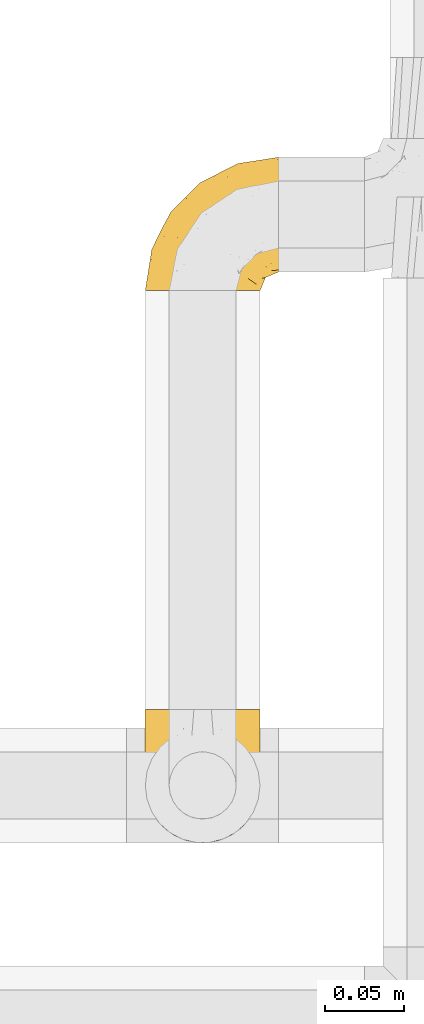
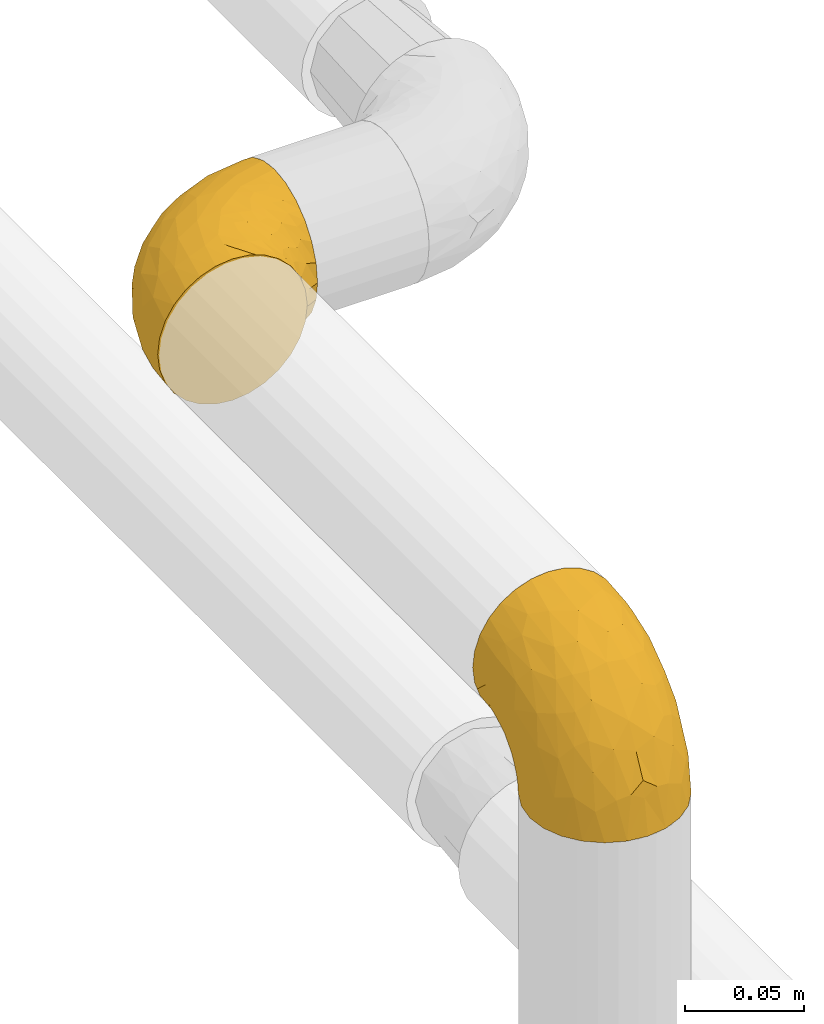
# One storey, part 21 of 39: 2 coverings.
"""IFC2X3 building model written with IfcOpenShell, lengths in millimetres."""

from ifc_helpers import new_model, entity, si_unit, converted_unit, derived_unit, direction, frame, origin, place, context, subcontext, project, spatial, faceted_brep, element, save


model = new_model("IFC2X3")

# Units and contexts
model_context = context("Model", 3, precision=0.01, world=origin(), true_north=direction((6.12303176911189e-17, 1.0)))
body_context = subcontext(model_context, "Body", "Model", "MODEL_VIEW")
ifc_project = project(units=[si_unit("LENGTHUNIT", "METRE", prefix="MILLI"), si_unit("AREAUNIT", "SQUARE_METRE"), si_unit("VOLUMEUNIT", "CUBIC_METRE"), converted_unit("PLANEANGLEUNIT", "DEGREE", entity("IfcRatioMeasure", 0.0174532925199433), si_unit("PLANEANGLEUNIT", "RADIAN"), dimensions=[0, 0, 0, 0, 0, 0, 0]), si_unit("MASSUNIT", "GRAM", prefix="KILO"), derived_unit("MASSDENSITYUNIT", [(si_unit("MASSUNIT", "GRAM", prefix="KILO"), 1), (si_unit("LENGTHUNIT", "METRE"), -3)]), derived_unit("MOMENTOFINERTIAUNIT", [(si_unit("LENGTHUNIT", "METRE"), 4)]), si_unit("TIMEUNIT", "SECOND"), si_unit("FREQUENCYUNIT", "HERTZ"), si_unit("THERMODYNAMICTEMPERATUREUNIT", "DEGREE_CELSIUS"), derived_unit("THERMALTRANSMITTANCEUNIT", [(si_unit("MASSUNIT", "GRAM", prefix="KILO"), 1), (si_unit("THERMODYNAMICTEMPERATUREUNIT", "KELVIN"), -1), (si_unit("TIMEUNIT", "SECOND"), -3)]), derived_unit("VOLUMETRICFLOWRATEUNIT", [(si_unit("LENGTHUNIT", "METRE"), 3), (si_unit("TIMEUNIT", "SECOND"), -1)]), derived_unit("MASSFLOWRATEUNIT", [(si_unit("MASSUNIT", "GRAM", prefix="KILO"), 1), (si_unit("TIMEUNIT", "SECOND"), -1)]), derived_unit("ROTATIONALFREQUENCYUNIT", [(si_unit("TIMEUNIT", "SECOND"), -1)]), si_unit("ELECTRICCURRENTUNIT", "AMPERE"), si_unit("ELECTRICVOLTAGEUNIT", "VOLT"), si_unit("POWERUNIT", "WATT"), si_unit("FORCEUNIT", "NEWTON", prefix="KILO"), si_unit("ILLUMINANCEUNIT", "LUX"), si_unit("LUMINOUSFLUXUNIT", "LUMEN"), si_unit("LUMINOUSINTENSITYUNIT", "CANDELA"), derived_unit("USERDEFINED", [(si_unit("MASSUNIT", "GRAM", prefix="KILO"), -1), (si_unit("LENGTHUNIT", "METRE"), -2), (si_unit("TIMEUNIT", "SECOND"), 3), (si_unit("LUMINOUSFLUXUNIT", "LUMEN"), 1)]), derived_unit("LINEARVELOCITYUNIT", [(si_unit("LENGTHUNIT", "METRE"), 1), (si_unit("TIMEUNIT", "SECOND"), -1)]), si_unit("PRESSUREUNIT", "PASCAL"), derived_unit("USERDEFINED", [(si_unit("LENGTHUNIT", "METRE"), -2), (si_unit("MASSUNIT", "GRAM", prefix="KILO"), 1), (si_unit("TIMEUNIT", "SECOND"), -2)]), derived_unit("LINEARFORCEUNIT", [(si_unit("MASSUNIT", "GRAM", prefix="KILO"), 1), (si_unit("LENGTHUNIT", "METRE"), 1), (si_unit("TIMEUNIT", "SECOND"), -2), (si_unit("LENGTHUNIT", "METRE"), -1)]), derived_unit("PLANARFORCEUNIT", [(si_unit("MASSUNIT", "GRAM", prefix="KILO"), 1), (si_unit("LENGTHUNIT", "METRE"), 1), (si_unit("TIMEUNIT", "SECOND"), -2), (si_unit("LENGTHUNIT", "METRE"), -2)])], contexts=[model_context])

# Site, building, storey
site_placement = place(None, origin())
site = spatial("IfcSite", under=ifc_project, at=site_placement, CompositionType="ELEMENT")
building_placement = place(site_placement, origin())
building = spatial("IfcBuilding", under=site, at=building_placement, CompositionType="ELEMENT")
storey_placement = place(building_placement, frame((0.0, 0.0, 24000.0)))
storey = spatial("IfcBuildingStorey", under=building, at=storey_placement, Name="07", CompositionType="ELEMENT", Elevation=24000.0)

# Coverings
covering_1_placement = place(storey_placement, frame((69427.22, 3185.76, 3362.2)))
element("IfcCovering", 1, at=covering_1_placement, inside=storey, Name=":ADSK_", ObjectType=":ADSK_", PredefinedType="INSULATION", context=body_context, shape_type="Brep", body=[
    faceted_brep([(37.8, 1.6, 74.0), (29.74, 1.6, 73.09), (22.08, 1.6, 70.41), (15.22, 1.6, 66.09), (9.49, 1.6, 60.36), (5.18, 1.6, 53.5), (2.5, 1.6, 45.85), (1.6, 1.6, 37.8), (2.5, 1.6, 29.74), (5.18, 1.6, 22.08), (9.5, 1.6, 15.22), (15.23, 1.6, 9.49), (22.09, 1.6, 5.18), (29.74, 1.6, 2.5), (37.8, 1.6, 1.6), (43.06, 1.6, 2.19), (45.85, 1.6, 2.5), (49.68, 1.6, 3.84), (53.51, 1.6, 5.18), (60.37, 1.6, 9.5), (66.1, 1.6, 15.23), (70.41, 1.6, 22.09), (73.09, 1.6, 29.74), (74.0, 1.6, 37.8), (73.09, 1.6, 45.85), (70.41, 1.6, 53.51), (66.09, 1.6, 60.37), (60.36, 1.6, 66.1), (53.5, 1.6, 70.41), (49.67, 1.6, 71.75), (45.85, 1.6, 73.09), (43.06, 1.6, 73.4), (85.8, 14.63, 28.43), (85.8, 18.25, 19.7), (85.8, 24.0, 12.2), (85.8, 27.75, 9.32), (85.8, 31.5, 6.45), (85.8, 35.86, 4.64), (85.8, 40.23, 2.83), (85.8, 44.31, 2.29), (85.8, 46.95, 1.94), (85.8, 49.6, 1.6), (85.8, 58.96, 2.83), (85.8, 67.7, 6.45), (85.8, 75.19, 12.2), (85.8, 80.95, 19.7), (85.8, 84.56, 28.43), (85.8, 85.8, 37.8), (85.8, 84.56, 47.16), (85.8, 80.95, 55.9), (85.8, 75.19, 63.39), (85.8, 67.7, 69.15), (85.8, 58.96, 72.76), (85.8, 49.6, 74.0), (85.8, 44.31, 73.3), (85.8, 40.23, 72.76), (85.8, 35.86, 70.95), (85.8, 31.5, 69.15), (85.8, 27.75, 66.27), (85.8, 24.0, 63.39), (85.8, 18.25, 55.9), (85.8, 14.63, 47.16), (85.8, 13.4, 37.8), (27.78, 59.61, 50.11), (26.99, 60.4, 37.8), (19.15, 51.32, 46.44), (59.78, 81.67, 37.8), (64.45, 82.49, 44.03), (67.99, 82.98, 37.8), (45.3, 73.87, 47.59), (53.86, 73.39, 57.17), (66.01, 81.11, 50.38), (70.92, 77.75, 58.65), (33.16, 16.46, 73.37), (49.16, 51.34, 71.27), (68.28, 63.37, 70.16), (50.64, 61.46, 66.97), (70.36, 54.83, 73.22), (67.43, 45.94, 74.0), (74.88, 47.42, 74.0), (77.61, 47.97, 74.0), (80.34, 48.51, 74.0), (65.68, 70.77, 64.86), (24.84, 15.75, 70.93), (11.5, 39.56, 45.19), (5.67, 21.48, 48.57), (13.35, 36.01, 54.32), (39.73, 34.58, 72.94), (41.45, 19.96, 74.0), (44.05, 23.86, 74.0), (46.65, 27.75, 74.0), (49.25, 31.64, 74.0), (51.85, 35.54, 74.0), (35.98, 46.13, 68.72), (57.18, 48.41, 73.34), (18.48, 16.74, 67.28), (13.36, 21.75, 61.7), (7.85, 16.31, 55.94), (4.42, 19.4, 37.8), (20.15, 48.77, 53.02), (31.91, 58.66, 57.31), (38.88, 7.05, 74.0), (39.97, 12.51, 74.0), (21.9, 34.87, 64.86), (22.4, 45.71, 59.15), (28.44, 30.95, 70.05), (41.69, 67.5, 55.98), (48.04, 75.69, 37.8), (33.67, 53.35, 63.54), (44.49, 64.73, 61.4), (5.72, 27.61, 37.8), (17.68, 51.09, 37.8), (11.7, 39.35, 37.8), (55.75, 38.14, 74.0), (59.64, 40.74, 74.0), (63.53, 43.34, 74.0), (36.3, 69.71, 37.8), (69.92, 30.92, 70.9), (69.03, 26.47, 69.2), (74.68, 24.1, 65.83), (79.55, 42.08, 73.31), (79.54, 27.56, 67.07), (81.25, 22.68, 62.53), (76.19, 12.9, 52.3), (72.4, 10.56, 54.94), (75.54, 9.38, 46.54), (63.7, 30.49, 72.08), (66.91, 37.21, 73.17), (72.9, 15.4, 59.32), (77.88, 16.56, 56.36), (80.8, 14.21, 48.99), (80.78, 19.1, 58.36), (60.93, 6.65, 66.05), (66.56, 9.22, 61.56), (58.7, 13.56, 68.98), (46.01, 10.43, 73.26), (80.23, 32.68, 70.05), (70.42, 40.02, 73.39), (74.75, 33.01, 70.87), (68.99, 13.09, 61.17), (51.42, 11.85, 71.9), (71.01, 20.93, 65.19), (76.08, 6.64, 37.8), (73.72, 5.68, 46.04), (71.61, 5.7, 52.15), (63.33, 14.76, 66.57), (77.45, 9.94, 37.8), (52.1, 25.2, 73.34), (50.98, 19.66, 72.91), (80.75, 11.31, 37.8), (76.87, 39.13, 72.75), (63.89, 24.56, 70.14), (57.77, 25.09, 72.14), (66.53, 18.54, 66.28), (57.73, 30.86, 73.22), (80.78, 19.1, 17.23), (80.8, 14.22, 26.6), (81.26, 22.68, 13.06), (38.88, 7.05, 1.6), (39.97, 12.51, 1.6), (73.72, 5.68, 29.56), (72.41, 10.57, 20.66), (71.61, 5.7, 23.45), (66.57, 9.22, 14.04), (74.88, 47.42, 1.6), (80.34, 48.51, 1.6), (83.07, 49.05, 1.6), (77.88, 16.56, 19.23), (76.2, 12.9, 23.3), (72.91, 15.39, 16.29), (77.2, 27.52, 8.09), (74.75, 33.0, 4.72), (80.23, 32.67, 5.54), (51.43, 11.86, 3.69), (76.87, 39.13, 2.84), (66.92, 37.21, 2.42), (69.93, 30.92, 4.69), (63.71, 30.49, 3.51), (70.42, 40.02, 2.2), (75.54, 9.38, 29.05), (79.55, 42.08, 2.29), (60.94, 6.65, 9.55), (69.0, 13.09, 14.43), (46.02, 10.43, 2.33), (57.77, 25.08, 3.45), (57.73, 30.85, 2.37), (63.89, 24.56, 5.45), (71.03, 20.93, 10.41), (51.53, 19.57, 2.81), (58.72, 13.56, 6.62), (41.45, 19.96, 1.6), (74.69, 24.1, 9.76), (63.35, 14.76, 9.03), (49.25, 31.64, 1.6), (56.44, 20.0, 4.15), (51.59, 25.27, 2.17), (44.05, 23.86, 1.6), (59.64, 40.74, 1.6), (55.75, 38.14, 1.6), (67.43, 45.94, 1.6), (63.53, 43.34, 1.6), (69.03, 26.46, 6.39), (66.54, 18.54, 9.32), (46.65, 27.75, 1.6), (51.85, 35.54, 1.6), (49.16, 51.33, 4.32), (70.36, 54.83, 2.37), (57.19, 48.41, 2.25), (22.41, 45.7, 16.43), (31.92, 58.67, 18.27), (33.68, 53.34, 12.04), (50.63, 61.46, 8.62), (35.99, 46.13, 6.87), (21.91, 34.86, 10.72), (39.73, 34.58, 2.64), (27.78, 59.61, 25.48), (41.7, 67.49, 19.59), (68.28, 63.37, 5.43), (64.45, 82.49, 31.57), (66.0, 81.11, 25.21), (28.45, 30.94, 5.53), (70.92, 77.75, 16.94), (65.68, 70.77, 10.73), (53.85, 73.39, 18.42), (13.35, 36.01, 21.26), (5.67, 21.48, 27.01), (11.5, 39.57, 30.39), (33.16, 16.45, 2.22), (13.37, 21.75, 13.88), (18.49, 16.74, 8.3), (45.3, 73.87, 28.0), (19.14, 51.31, 29.14), (20.15, 48.77, 22.56), (7.85, 16.32, 19.64), (44.48, 64.71, 14.18), (24.85, 15.75, 4.66)], [[[0, 1, 2, 3, 4, 5, 6, 7, 8, 9, 10, 11, 12, 13, 14, 15, 16, 17, 18, 19, 20, 21, 22, 23, 24, 25, 26, 27, 28, 29, 30, 31]], [[32, 33, 34, 35, 36, 37, 38, 39, 40, 41, 42, 43, 44, 45, 46, 47, 48, 49, 50, 51, 52, 53, 54, 55, 56, 57, 58, 59, 60, 61, 62]], [[63, 64, 65]], [[66, 67, 68]], [[69, 70, 71]], [[71, 70, 72]], [[73, 1, 0]], [[74, 75, 76]], [[49, 48, 71]], [[77, 78, 79, 80, 81, 53]], [[50, 82, 51]], [[72, 50, 49]], [[2, 1, 83]], [[84, 85, 86]], [[87, 88, 89, 90, 91, 92]], [[53, 52, 77]], [[93, 74, 76]], [[5, 85, 6]], [[94, 78, 77]], [[95, 3, 2]], [[95, 96, 3]], [[75, 51, 82]], [[85, 5, 97]], [[50, 72, 82]], [[97, 5, 4]], [[85, 98, 6]], [[94, 87, 92]], [[74, 77, 75]], [[99, 100, 63]], [[96, 4, 3]], [[73, 0, 101, 102, 88]], [[96, 103, 104]], [[48, 68, 67]], [[84, 99, 65]], [[105, 83, 73]], [[105, 95, 83]], [[100, 106, 63]], [[86, 96, 104]], [[97, 86, 85]], [[67, 107, 69]], [[100, 108, 109]], [[84, 110, 85]], [[93, 87, 74]], [[96, 95, 103]], [[69, 71, 67]], [[70, 69, 106]], [[4, 96, 97]], [[86, 97, 96]], [[83, 95, 2]], [[103, 95, 105]], [[93, 103, 105]], [[103, 108, 104]], [[75, 77, 52]], [[94, 77, 74]], [[51, 75, 52]], [[75, 82, 76]], [[109, 82, 70]], [[93, 76, 108]], [[88, 87, 73]], [[105, 73, 87]], [[84, 86, 99]], [[84, 111, 112, 110]], [[98, 85, 110]], [[98, 7, 6]], [[73, 83, 1]], [[71, 72, 49]], [[82, 72, 70]], [[87, 94, 74]], [[94, 92, 113, 114, 115, 78]], [[48, 47, 68]], [[48, 67, 71]], [[100, 104, 108]], [[99, 86, 104]], [[109, 108, 76]], [[100, 109, 106]], [[82, 109, 76]], [[106, 109, 70]], [[100, 99, 104]], [[99, 63, 65]], [[69, 116, 63]], [[111, 84, 65]], [[64, 63, 116]], [[64, 111, 65]], [[63, 106, 69]], [[103, 93, 108]], [[87, 93, 105]], [[107, 67, 66]], [[107, 116, 69]], [[117, 118, 119]], [[80, 120, 55]], [[121, 119, 122]], [[120, 56, 55]], [[123, 124, 125]], [[114, 126, 127]], [[101, 0, 31, 30, 102]], [[123, 128, 124]], [[129, 123, 130]], [[60, 122, 131]], [[132, 133, 134]], [[29, 28, 135]], [[131, 61, 60]], [[122, 60, 59]], [[136, 137, 138]], [[124, 128, 139]], [[132, 27, 26]], [[131, 130, 61]], [[140, 135, 28]], [[102, 29, 135]], [[119, 118, 141]], [[58, 136, 121]], [[140, 28, 27]], [[54, 53, 81, 80, 55]], [[23, 142, 143]], [[24, 144, 25]], [[25, 144, 133]], [[26, 25, 133]], [[134, 133, 145]], [[125, 142, 146]], [[124, 143, 125]], [[147, 90, 148]], [[124, 144, 143]], [[149, 125, 146]], [[150, 57, 56]], [[137, 78, 115]], [[130, 62, 61]], [[132, 140, 27]], [[151, 152, 153]], [[140, 134, 148]], [[148, 89, 140]], [[120, 78, 150]], [[115, 127, 137]], [[137, 136, 150]], [[78, 120, 80, 79]], [[150, 56, 120]], [[91, 154, 92]], [[127, 117, 138]], [[144, 24, 143]], [[133, 144, 124]], [[152, 91, 147]], [[145, 152, 134]], [[23, 143, 24]], [[142, 125, 143]], [[130, 125, 149]], [[128, 123, 129]], [[141, 129, 119]], [[124, 139, 133]], [[125, 130, 123]], [[62, 130, 149]], [[128, 153, 139]], [[145, 139, 153]], [[92, 154, 113]], [[127, 115, 114]], [[117, 127, 126]], [[118, 117, 126]], [[121, 117, 119]], [[138, 137, 127]], [[78, 137, 150]], [[151, 118, 126]], [[118, 151, 141]], [[153, 128, 141]], [[129, 141, 128]], [[102, 30, 29]], [[140, 88, 135]], [[88, 102, 135]], [[133, 132, 26]], [[140, 132, 134]], [[121, 122, 59]], [[131, 119, 129]], [[121, 59, 58]], [[121, 138, 117]], [[136, 58, 57]], [[150, 136, 57]], [[121, 136, 138]], [[119, 131, 122]], [[131, 129, 130]], [[139, 145, 133]], [[152, 145, 153]], [[89, 148, 90]], [[89, 88, 140]], [[147, 134, 152]], [[134, 147, 148]], [[126, 114, 113]], [[152, 154, 91]], [[91, 90, 147]], [[151, 153, 141]], [[154, 151, 126]], [[151, 154, 152]], [[113, 154, 126]], [[155, 32, 156]], [[33, 157, 34]], [[62, 149, 156]], [[15, 14, 158, 159, 16]], [[160, 23, 22]], [[161, 162, 163]], [[40, 39, 38, 164, 165, 166, 41]], [[167, 168, 169]], [[157, 170, 34]], [[171, 172, 170]], [[18, 173, 19]], [[174, 37, 36]], [[175, 176, 177]], [[178, 171, 175]], [[146, 179, 149]], [[168, 179, 161]], [[161, 160, 162]], [[162, 160, 22]], [[38, 37, 180]], [[20, 19, 181]], [[21, 20, 163]], [[161, 182, 169]], [[18, 183, 173]], [[184, 185, 186]], [[169, 187, 167]], [[188, 189, 173]], [[159, 190, 183]], [[17, 159, 183]], [[156, 179, 168]], [[191, 157, 155]], [[192, 163, 189]], [[21, 162, 22]], [[146, 142, 179]], [[181, 163, 20]], [[185, 184, 193]], [[178, 172, 171]], [[167, 156, 168]], [[184, 194, 195]], [[181, 173, 189]], [[173, 196, 188]], [[197, 177, 198]], [[199, 164, 180]], [[180, 164, 38]], [[200, 178, 175]], [[37, 174, 180]], [[199, 180, 174]], [[175, 197, 200]], [[177, 176, 201]], [[163, 162, 21]], [[160, 161, 179]], [[192, 184, 202]], [[194, 189, 188]], [[179, 142, 160]], [[23, 160, 142]], [[169, 168, 161]], [[155, 156, 167]], [[182, 161, 163]], [[202, 186, 187]], [[62, 156, 32]], [[179, 156, 149]], [[192, 182, 163]], [[202, 169, 182]], [[176, 175, 171]], [[174, 178, 199]], [[197, 175, 177]], [[170, 176, 171]], [[201, 176, 191]], [[199, 178, 200]], [[178, 174, 172]], [[187, 201, 191]], [[201, 187, 186]], [[167, 187, 191]], [[169, 202, 187]], [[173, 183, 190]], [[17, 16, 159]], [[173, 181, 19]], [[163, 181, 189]], [[155, 157, 33]], [[170, 157, 191]], [[176, 170, 191]], [[35, 170, 172]], [[35, 172, 36]], [[34, 170, 35]], [[174, 36, 172]], [[32, 155, 33]], [[191, 155, 167]], [[192, 189, 194]], [[182, 192, 202]], [[185, 198, 177]], [[183, 18, 17]], [[196, 173, 190]], [[196, 203, 188]], [[201, 186, 177]], [[202, 184, 186]], [[188, 195, 194]], [[204, 185, 193]], [[188, 203, 195]], [[192, 194, 184]], [[203, 193, 195]], [[184, 195, 193]], [[198, 185, 204]], [[186, 185, 177]], [[205, 206, 207]], [[208, 209, 210]], [[210, 211, 212]], [[210, 213, 208]], [[214, 204, 193, 203, 196, 190]], [[206, 41, 166, 165, 164, 199]], [[215, 216, 209]], [[206, 217, 42]], [[218, 46, 219]], [[207, 214, 205]], [[212, 214, 220]], [[221, 219, 45]], [[45, 219, 46]], [[221, 222, 223]], [[224, 225, 226]], [[222, 44, 43]], [[222, 217, 211]], [[220, 214, 227]], [[227, 190, 159, 158, 14]], [[217, 43, 42]], [[14, 13, 227]], [[225, 9, 8]], [[10, 228, 11]], [[11, 229, 12]], [[208, 213, 228]], [[228, 229, 11]], [[230, 219, 223]], [[231, 232, 226]], [[231, 64, 215]], [[225, 233, 9]], [[229, 213, 220]], [[233, 10, 9]], [[110, 225, 98]], [[41, 206, 42]], [[222, 211, 234]], [[224, 228, 233]], [[225, 8, 98]], [[221, 45, 44]], [[226, 110, 112, 111]], [[12, 229, 235]], [[46, 218, 68]], [[230, 107, 218]], [[223, 234, 216]], [[107, 66, 218]], [[224, 233, 225]], [[228, 10, 233]], [[213, 229, 228]], [[235, 229, 220]], [[208, 228, 224]], [[212, 213, 210]], [[207, 206, 199]], [[205, 211, 217]], [[205, 217, 206]], [[43, 217, 222]], [[212, 211, 205]], [[210, 209, 234]], [[227, 13, 235]], [[214, 190, 227]], [[110, 226, 225]], [[232, 231, 215]], [[8, 7, 98]], [[227, 235, 220]], [[13, 12, 235]], [[222, 221, 44]], [[219, 221, 223]], [[207, 199, 200, 197, 198, 204]], [[214, 207, 204]], [[68, 218, 66]], [[68, 47, 46]], [[230, 218, 219]], [[224, 232, 208]], [[208, 232, 209]], [[216, 215, 230]], [[210, 234, 211]], [[216, 234, 209]], [[222, 234, 223]], [[226, 232, 224]], [[209, 232, 215]], [[226, 111, 231]], [[64, 116, 215]], [[231, 111, 64]], [[116, 230, 215]], [[230, 223, 216]], [[214, 212, 205]], [[213, 212, 220]], [[230, 116, 107]]]),
])
covering_2_placement = place(storey_placement, frame((69427.22, 2837.56, 3350.4)))
element("IfcCovering", 2, at=covering_2_placement, inside=storey, Name=":ADSK_", ObjectType=":ADSK_", PredefinedType="INSULATION", context=body_context, shape_type="Brep", body=[
    faceted_brep([(1.6, 85.8, 49.6), (2.5, 85.8, 57.65), (5.18, 85.8, 65.31), (9.5, 85.8, 72.17), (15.23, 85.8, 77.9), (22.09, 85.8, 82.21), (29.74, 85.8, 84.89), (37.8, 85.8, 85.8), (45.85, 85.8, 84.89), (53.51, 85.8, 82.21), (60.37, 85.8, 77.89), (66.1, 85.8, 72.16), (70.41, 85.8, 65.3), (73.09, 85.8, 57.65), (74.0, 85.8, 49.6), (73.4, 85.8, 44.33), (73.09, 85.8, 41.54), (71.75, 85.8, 37.71), (70.41, 85.8, 33.88), (66.09, 85.8, 27.02), (60.36, 85.8, 21.29), (53.5, 85.8, 16.98), (45.85, 85.8, 14.3), (37.8, 85.8, 13.4), (29.74, 85.8, 14.3), (22.08, 85.8, 16.98), (15.22, 85.8, 21.3), (9.49, 85.8, 27.03), (5.18, 85.8, 33.89), (3.84, 85.8, 37.72), (2.5, 85.8, 41.54), (2.19, 85.8, 44.33), (47.16, 72.76, 1.6), (55.9, 69.15, 1.6), (63.39, 63.39, 1.6), (66.27, 59.64, 1.6), (69.15, 55.9, 1.6), (70.95, 51.53, 1.6), (72.76, 47.16, 1.6), (73.3, 43.08, 1.6), (73.65, 40.44, 1.6), (74.0, 37.8, 1.6), (72.76, 28.43, 1.6), (69.15, 19.7, 1.6), (63.39, 12.2, 1.6), (55.9, 6.45, 1.6), (47.16, 2.83, 1.6), (37.8, 1.6, 1.6), (28.43, 2.83, 1.6), (19.7, 6.45, 1.6), (12.2, 12.2, 1.6), (6.45, 19.7, 1.6), (2.83, 28.43, 1.6), (1.6, 37.8, 1.6), (2.29, 43.08, 1.6), (2.83, 47.16, 1.6), (4.64, 51.53, 1.6), (6.45, 55.9, 1.6), (9.32, 59.64, 1.6), (12.2, 63.39, 1.6), (19.7, 69.15, 1.6), (28.43, 72.76, 1.6), (37.8, 74.0, 1.6), (25.48, 27.78, 59.61), (37.8, 26.99, 60.4), (29.15, 36.07, 68.25), (37.8, 5.72, 27.61), (31.57, 4.9, 22.94), (37.8, 4.42, 19.4), (28.0, 13.52, 42.09), (18.42, 14.0, 33.53), (25.21, 6.28, 21.38), (16.94, 9.64, 16.47), (2.22, 70.93, 54.23), (4.32, 36.05, 38.23), (5.43, 24.02, 19.11), (8.62, 25.93, 36.76), (2.37, 32.56, 17.03), (1.6, 41.45, 19.96), (1.6, 39.97, 12.51), (1.6, 39.42, 9.78), (1.6, 38.88, 7.05), (10.73, 16.62, 21.71), (4.66, 71.64, 62.55), (30.4, 47.83, 75.89), (27.02, 65.91, 81.72), (21.27, 51.38, 74.04), (2.65, 52.81, 47.66), (1.6, 67.43, 45.94), (1.6, 63.53, 43.34), (1.6, 59.64, 40.74), (1.6, 55.75, 38.14), (1.6, 51.85, 35.54), (6.87, 41.26, 51.41), (2.25, 38.98, 30.21), (8.31, 70.65, 68.91), (13.89, 65.64, 74.03), (19.66, 71.08, 79.54), (37.8, 67.99, 82.98), (22.57, 38.62, 67.24), (18.28, 28.73, 55.48), (1.6, 80.34, 48.51), (1.6, 74.88, 47.42), (10.73, 52.52, 65.49), (16.44, 41.68, 64.99), (5.54, 56.44, 58.95), (19.61, 19.89, 45.7), (37.8, 11.7, 39.35), (12.05, 34.04, 53.72), (14.19, 22.66, 42.9), (37.8, 59.78, 81.67), (37.8, 36.3, 69.71), (37.8, 48.04, 75.69), (1.6, 49.25, 31.64), (1.6, 46.65, 27.75), (1.6, 44.05, 23.86), (37.8, 17.68, 51.09), (4.69, 56.47, 17.47), (6.39, 60.92, 18.36), (9.76, 63.29, 12.71), (2.29, 45.31, 7.84), (8.52, 59.83, 7.85), (13.06, 64.71, 6.14), (23.29, 74.49, 11.2), (20.65, 76.83, 14.99), (29.05, 78.01, 11.85), (3.51, 56.9, 23.69), (2.42, 50.18, 20.48), (16.27, 71.99, 14.49), (19.23, 70.83, 9.51), (26.6, 73.18, 6.6), (17.24, 68.29, 6.61), (9.54, 80.74, 26.46), (14.03, 78.17, 20.83), (6.61, 73.83, 28.69), (2.33, 76.96, 41.38), (5.54, 54.72, 7.16), (2.2, 47.37, 16.97), (4.72, 54.39, 12.64), (14.42, 74.3, 18.4), (3.69, 75.54, 35.97), (10.4, 66.46, 16.38), (37.8, 80.75, 11.31), (29.55, 81.71, 13.68), (23.44, 81.69, 15.78), (9.02, 72.63, 24.06), (37.8, 77.45, 9.94), (2.25, 62.19, 35.3), (2.68, 67.73, 36.41), (37.8, 76.08, 6.64), (2.84, 48.26, 10.52), (5.45, 62.83, 23.5), (3.45, 62.31, 29.62), (9.31, 68.86, 20.86), (2.37, 56.53, 29.66), (58.36, 68.29, 6.61), (48.99, 73.17, 6.59), (62.53, 64.71, 6.13), (74.0, 80.34, 48.51), (74.0, 74.88, 47.42), (46.03, 81.71, 13.67), (54.93, 76.83, 14.98), (52.14, 81.69, 15.78), (61.55, 78.17, 20.82), (74.0, 39.97, 12.51), (74.0, 38.88, 7.05), (74.0, 38.34, 4.32), (56.36, 70.83, 9.51), (52.29, 74.49, 11.19), (59.3, 72.0, 14.48), (67.5, 59.87, 10.19), (70.87, 54.39, 12.64), (70.05, 54.72, 7.16), (71.9, 75.53, 35.96), (72.75, 48.26, 10.52), (73.17, 50.18, 20.47), (70.9, 56.47, 17.47), (72.08, 56.9, 23.68), (73.39, 47.37, 16.97), (46.54, 78.01, 11.85), (73.31, 45.31, 7.84), (66.04, 80.74, 26.45), (61.17, 74.3, 18.39), (73.26, 76.96, 41.37), (72.14, 62.32, 29.62), (73.22, 56.54, 29.66), (70.14, 62.83, 23.5), (65.18, 66.46, 16.36), (72.78, 67.82, 35.87), (68.97, 73.83, 28.67), (74.0, 67.43, 45.94), (65.83, 63.29, 12.7), (66.56, 72.63, 24.04), (74.0, 55.75, 38.14), (71.44, 67.39, 30.95), (73.42, 62.12, 35.8), (74.0, 63.53, 43.34), (74.0, 46.65, 27.75), (74.0, 49.25, 31.64), (74.0, 41.45, 19.96), (74.0, 44.05, 23.86), (69.2, 60.93, 18.36), (66.27, 68.85, 20.85), (74.0, 59.64, 40.74), (74.0, 51.85, 35.54), (71.27, 36.06, 38.23), (73.22, 32.56, 17.03), (73.34, 38.98, 30.2), (59.16, 41.69, 64.98), (57.32, 28.73, 55.47), (63.55, 34.05, 53.71), (66.97, 25.93, 36.76), (68.72, 41.26, 51.4), (64.87, 52.53, 65.48), (72.95, 52.81, 47.66), (50.11, 27.78, 59.61), (56.0, 19.9, 45.69), (70.16, 24.02, 19.11), (44.03, 4.9, 22.94), (50.38, 6.28, 21.39), (70.06, 56.45, 58.94), (58.65, 9.64, 16.47), (64.86, 16.62, 21.71), (57.17, 14.0, 33.54), (54.33, 51.38, 74.04), (48.58, 65.91, 81.72), (45.2, 47.82, 75.89), (73.37, 70.94, 54.23), (61.71, 65.64, 74.02), (67.29, 70.65, 68.9), (47.59, 13.52, 42.09), (46.45, 36.08, 68.25), (53.03, 38.62, 67.24), (55.95, 71.07, 79.54), (61.41, 22.68, 42.91), (70.93, 71.64, 62.54)], [[[0, 1, 2, 3, 4, 5, 6, 7, 8, 9, 10, 11, 12, 13, 14, 15, 16, 17, 18, 19, 20, 21, 22, 23, 24, 25, 26, 27, 28, 29, 30, 31]], [[32, 33, 34, 35, 36, 37, 38, 39, 40, 41, 42, 43, 44, 45, 46, 47, 48, 49, 50, 51, 52, 53, 54, 55, 56, 57, 58, 59, 60, 61, 62]], [[63, 64, 65]], [[66, 67, 68]], [[69, 70, 71]], [[71, 70, 72]], [[73, 1, 0]], [[74, 75, 76]], [[49, 48, 71]], [[77, 78, 79, 80, 81, 53]], [[50, 82, 51]], [[72, 50, 49]], [[2, 1, 83]], [[84, 85, 86]], [[87, 88, 89, 90, 91, 92]], [[53, 52, 77]], [[93, 74, 76]], [[5, 85, 6]], [[94, 78, 77]], [[95, 3, 2]], [[95, 96, 3]], [[75, 51, 82]], [[85, 5, 97]], [[50, 72, 82]], [[97, 5, 4]], [[85, 98, 6]], [[94, 87, 92]], [[74, 77, 75]], [[99, 100, 63]], [[96, 4, 3]], [[73, 0, 101, 102, 88]], [[96, 103, 104]], [[48, 68, 67]], [[84, 99, 65]], [[105, 83, 73]], [[105, 95, 83]], [[100, 106, 63]], [[86, 96, 104]], [[97, 86, 85]], [[67, 107, 69]], [[100, 108, 109]], [[84, 110, 85]], [[93, 87, 74]], [[96, 95, 103]], [[69, 71, 67]], [[70, 69, 106]], [[4, 96, 97]], [[86, 97, 96]], [[83, 95, 2]], [[103, 95, 105]], [[93, 103, 105]], [[103, 108, 104]], [[75, 77, 52]], [[94, 77, 74]], [[51, 75, 52]], [[75, 82, 76]], [[109, 82, 70]], [[93, 76, 108]], [[88, 87, 73]], [[105, 73, 87]], [[84, 86, 99]], [[84, 111, 112, 110]], [[98, 85, 110]], [[98, 7, 6]], [[73, 83, 1]], [[71, 72, 49]], [[82, 72, 70]], [[87, 94, 74]], [[94, 92, 113, 114, 115, 78]], [[48, 47, 68]], [[48, 67, 71]], [[100, 104, 108]], [[99, 86, 104]], [[109, 108, 76]], [[100, 109, 106]], [[82, 109, 76]], [[106, 109, 70]], [[100, 99, 104]], [[99, 63, 65]], [[69, 116, 63]], [[111, 84, 65]], [[64, 63, 116]], [[64, 111, 65]], [[63, 106, 69]], [[103, 93, 108]], [[87, 93, 105]], [[107, 67, 66]], [[107, 116, 69]], [[117, 118, 119]], [[80, 120, 55]], [[121, 119, 122]], [[120, 56, 55]], [[123, 124, 125]], [[114, 126, 127]], [[101, 0, 31, 30, 102]], [[123, 128, 124]], [[129, 123, 130]], [[60, 122, 131]], [[132, 133, 134]], [[29, 28, 135]], [[131, 61, 60]], [[122, 60, 59]], [[136, 137, 138]], [[124, 128, 139]], [[132, 27, 26]], [[131, 130, 61]], [[140, 135, 28]], [[102, 29, 135]], [[119, 118, 141]], [[58, 136, 121]], [[140, 28, 27]], [[54, 53, 81, 80, 55]], [[23, 142, 143]], [[24, 144, 25]], [[25, 144, 133]], [[26, 25, 133]], [[134, 133, 145]], [[125, 142, 146]], [[124, 143, 125]], [[147, 90, 148]], [[124, 144, 143]], [[149, 125, 146]], [[150, 57, 56]], [[137, 78, 115]], [[130, 62, 61]], [[132, 140, 27]], [[151, 152, 153]], [[140, 134, 148]], [[148, 89, 140]], [[120, 78, 150]], [[115, 127, 137]], [[137, 136, 150]], [[78, 120, 80, 79]], [[150, 56, 120]], [[152, 151, 154]], [[127, 117, 138]], [[144, 24, 143]], [[133, 144, 124]], [[152, 91, 147]], [[145, 152, 134]], [[23, 143, 24]], [[142, 125, 143]], [[130, 125, 149]], [[128, 123, 129]], [[141, 129, 119]], [[124, 139, 133]], [[125, 130, 123]], [[62, 130, 149]], [[128, 153, 139]], [[145, 139, 153]], [[92, 154, 113]], [[127, 115, 114]], [[117, 127, 126]], [[118, 117, 126]], [[121, 117, 119]], [[138, 137, 127]], [[78, 137, 150]], [[151, 118, 126]], [[118, 151, 141]], [[153, 128, 141]], [[129, 141, 128]], [[102, 30, 29]], [[140, 88, 135]], [[88, 102, 135]], [[133, 132, 26]], [[140, 132, 134]], [[121, 122, 59]], [[131, 119, 129]], [[121, 59, 58]], [[121, 138, 117]], [[136, 58, 57]], [[150, 136, 57]], [[121, 136, 138]], [[119, 131, 122]], [[131, 129, 130]], [[139, 145, 133]], [[152, 145, 153]], [[89, 148, 90]], [[89, 88, 140]], [[147, 134, 152]], [[134, 147, 148]], [[126, 114, 113]], [[152, 154, 91]], [[91, 90, 147]], [[151, 153, 141]], [[154, 151, 126]], [[113, 154, 126]], [[91, 154, 92]], [[155, 32, 156]], [[33, 157, 34]], [[62, 149, 156]], [[15, 14, 158, 159, 16]], [[160, 23, 22]], [[161, 162, 163]], [[40, 39, 38, 164, 165, 166, 41]], [[167, 168, 169]], [[157, 170, 34]], [[171, 172, 170]], [[18, 173, 19]], [[174, 37, 36]], [[175, 176, 177]], [[178, 171, 175]], [[146, 179, 149]], [[168, 179, 161]], [[161, 160, 162]], [[162, 160, 22]], [[38, 37, 180]], [[20, 19, 181]], [[21, 20, 163]], [[161, 182, 169]], [[18, 183, 173]], [[184, 185, 186]], [[169, 187, 167]], [[188, 189, 173]], [[159, 190, 183]], [[17, 159, 183]], [[156, 179, 168]], [[191, 157, 155]], [[192, 163, 189]], [[21, 162, 22]], [[146, 142, 179]], [[181, 163, 20]], [[185, 184, 193]], [[178, 172, 171]], [[167, 156, 168]], [[184, 194, 195]], [[181, 173, 189]], [[173, 196, 188]], [[197, 177, 198]], [[199, 164, 180]], [[180, 164, 38]], [[200, 178, 175]], [[37, 174, 180]], [[199, 180, 174]], [[175, 197, 200]], [[177, 176, 201]], [[163, 162, 21]], [[160, 161, 179]], [[192, 184, 202]], [[194, 189, 188]], [[179, 142, 160]], [[23, 160, 142]], [[169, 168, 161]], [[155, 156, 167]], [[182, 161, 163]], [[202, 186, 187]], [[62, 156, 32]], [[179, 156, 149]], [[192, 182, 163]], [[202, 169, 182]], [[176, 175, 171]], [[174, 178, 199]], [[197, 175, 177]], [[170, 176, 171]], [[201, 176, 191]], [[199, 178, 200]], [[178, 174, 172]], [[187, 201, 191]], [[201, 187, 186]], [[167, 187, 191]], [[169, 202, 187]], [[173, 183, 190]], [[17, 16, 159]], [[173, 181, 19]], [[163, 181, 189]], [[155, 157, 33]], [[170, 157, 191]], [[176, 170, 191]], [[35, 170, 172]], [[35, 172, 36]], [[34, 170, 35]], [[174, 36, 172]], [[32, 155, 33]], [[191, 155, 167]], [[192, 189, 194]], [[182, 192, 202]], [[185, 198, 177]], [[183, 18, 17]], [[196, 173, 190]], [[196, 203, 188]], [[201, 186, 177]], [[202, 184, 186]], [[188, 195, 194]], [[204, 185, 193]], [[188, 203, 195]], [[192, 194, 184]], [[203, 193, 195]], [[184, 195, 193]], [[198, 185, 204]], [[186, 185, 177]], [[205, 206, 207]], [[208, 209, 210]], [[210, 211, 212]], [[210, 213, 208]], [[214, 204, 193, 203, 196, 190]], [[206, 41, 166, 165, 164, 199]], [[215, 216, 209]], [[206, 217, 42]], [[218, 46, 219]], [[207, 214, 205]], [[212, 214, 220]], [[221, 219, 45]], [[45, 219, 46]], [[221, 222, 223]], [[224, 225, 226]], [[222, 44, 43]], [[222, 217, 211]], [[220, 214, 227]], [[227, 190, 159, 158, 14]], [[217, 43, 42]], [[14, 13, 227]], [[225, 9, 8]], [[10, 228, 11]], [[11, 229, 12]], [[208, 213, 228]], [[228, 229, 11]], [[230, 219, 223]], [[231, 232, 226]], [[231, 64, 215]], [[225, 233, 9]], [[229, 213, 220]], [[233, 10, 9]], [[110, 225, 98]], [[41, 206, 42]], [[222, 211, 234]], [[224, 228, 233]], [[225, 8, 98]], [[221, 45, 44]], [[226, 110, 112, 111]], [[12, 229, 235]], [[46, 218, 68]], [[230, 107, 218]], [[223, 234, 216]], [[107, 66, 218]], [[224, 233, 225]], [[228, 10, 233]], [[213, 229, 228]], [[235, 229, 220]], [[208, 228, 224]], [[212, 213, 210]], [[207, 206, 199]], [[205, 211, 217]], [[205, 217, 206]], [[43, 217, 222]], [[212, 211, 205]], [[210, 209, 234]], [[227, 13, 235]], [[214, 190, 227]], [[110, 226, 225]], [[232, 231, 215]], [[8, 7, 98]], [[227, 235, 220]], [[13, 12, 235]], [[222, 221, 44]], [[219, 221, 223]], [[207, 199, 200, 197, 198, 204]], [[214, 207, 204]], [[68, 218, 66]], [[68, 47, 46]], [[230, 218, 219]], [[224, 232, 208]], [[208, 232, 209]], [[216, 215, 230]], [[210, 234, 211]], [[216, 234, 209]], [[222, 234, 223]], [[226, 232, 224]], [[209, 232, 215]], [[226, 111, 231]], [[64, 116, 215]], [[231, 111, 64]], [[116, 230, 215]], [[230, 223, 216]], [[214, 212, 205]], [[213, 212, 220]], [[230, 116, 107]]]),
])

save(model, "model.ifc")
